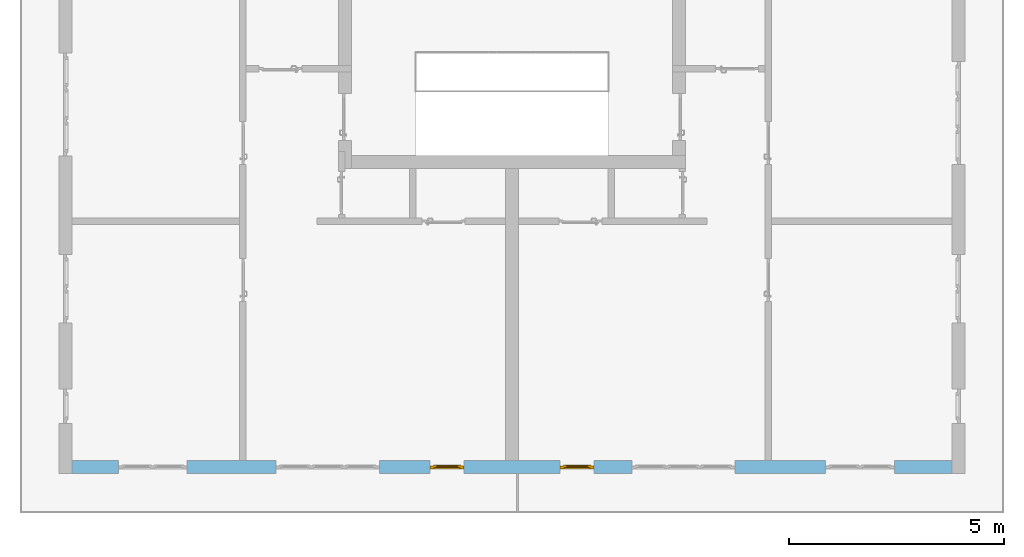
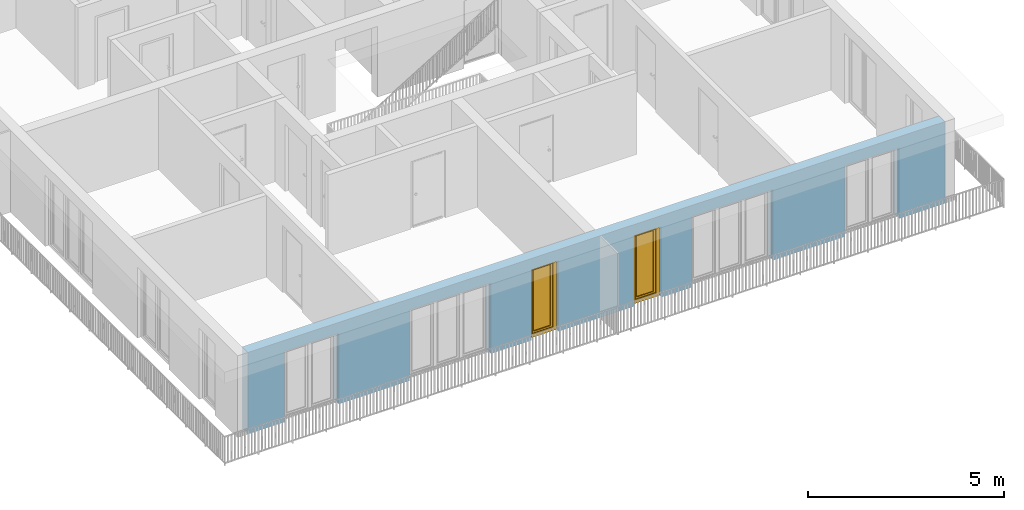
# One storey, part 10 of 54: 2 windows, 6 openings, plus 1 element that does not belong to this part.
"""IFC4 building model written with IfcOpenShell, lengths in metres."""

from ifc_helpers import new_model, entity, si_unit, converted_unit, derived_unit, direction, frame, origin_with_axes, place, context, subcontext, project, spatial, polygons, source, transform, mapped, material, type_object, element, fill, save


model = new_model("IFC4")

# Units and contexts
model_context = context("Model", 3, precision=1e-05, world=origin_with_axes(), true_north=direction((0.0, 1.0)))
body_context = subcontext(model_context, "Body", "Model", "MODEL_VIEW")
ifc_project = project(units=[si_unit("LENGTHUNIT", "METRE"), si_unit("AREAUNIT", "SQUARE_METRE"), si_unit("VOLUMEUNIT", "CUBIC_METRE"), converted_unit("PLANEANGLEUNIT", "DEGREE", entity("IfcPlaneAngleMeasure", 0.0174532925199), si_unit("PLANEANGLEUNIT", "RADIAN"), dimensions=[0, 0, 0, 0, 0, 0, 0]), converted_unit("TIMEUNIT", "Year", entity("IfcTimeMeasure", 31556926.0), si_unit("TIMEUNIT", "SECOND"), dimensions=[0, 0, 1, 0, 0, 0, 0]), si_unit("MASSUNIT", "GRAM", prefix="KILO"), si_unit("THERMODYNAMICTEMPERATUREUNIT", "DEGREE_CELSIUS"), si_unit("LUMINOUSINTENSITYUNIT", "LUMEN"), si_unit("ENERGYUNIT", "JOULE", prefix="MEGA"), derived_unit("THERMALCONDUCTANCEUNIT", [(si_unit("POWERUNIT", "WATT"), 1), (si_unit("LENGTHUNIT", "METRE"), -1), (si_unit("THERMODYNAMICTEMPERATUREUNIT", "KELVIN"), -1)]), derived_unit("SPECIFICHEATCAPACITYUNIT", [(si_unit("ENERGYUNIT", "JOULE"), 1), (si_unit("MASSUNIT", "GRAM", prefix="KILO"), -1), (si_unit("THERMODYNAMICTEMPERATUREUNIT", "KELVIN"), -1)]), derived_unit("MASSDENSITYUNIT", [(si_unit("MASSUNIT", "GRAM", prefix="KILO"), 1), (si_unit("VOLUMEUNIT", "CUBIC_METRE"), -1)])], contexts=[model_context])

# Site, building, storey
site_placement = place(None, origin_with_axes())
site = spatial("IfcSite", under=ifc_project, at=site_placement, CompositionType="ELEMENT")
building_placement = place(site_placement, origin_with_axes())
building = spatial("IfcBuilding", under=site, at=building_placement, CompositionType="ELEMENT")
storey_placement = place(building_placement, frame((0.0, 0.0, 6.29), z_axis=(0.0, 0.0, 1.0), x_axis=(1.0, 0.0, 0.0)))
storey = spatial("IfcBuildingStorey", under=building, at=storey_placement, Name="2. Geschoss", CompositionType="ELEMENT", Elevation=6.29)

# Wall, openings, windows
ifc_material = material()
wall_type = type_object("IfcWallType", Name="300", PredefinedType="NOTDEFINED")
wall_placement = place(storey_placement, frame((9.3378006196, -9.92881223104, 0.0), z_axis=(0.0, 0.0, 1.0), x_axis=(-1.0, 0.0, 0.0)))
wall = element("IfcWall", 1, at=wall_placement, inside=storey, type_object=wall_type, material=ifc_material, Name="Wand-001", PredefinedType="NOTDEFINED", context=body_context, shape_type="Tessellation", body=[
    polygons([(12.4515538751, -0.3, 2.2), (12.4515538751, -0.3, 0.0), (13.63, -0.3, 0.0), (13.63, -0.3, 2.2), (16.03, -0.3, 2.2), (16.03, -0.3, 0.0), (18.0998837323, -0.3, 0.0), (18.0998837323, -0.3, 2.2), (19.6998837323, -0.3, 2.2), (19.6998837323, -0.3, 0.0), (20.78, -0.3, 0.0), (20.78, -0.3, 2.54), (0.3, -0.3, 2.54), (0.3, -0.3, 0.0), (1.6378225413, -0.3, 0.0), (1.6378225413, -0.3, 2.2), (3.2378225413, -0.3, 2.2), (3.2378225413, -0.3, 0.0), (5.35, -0.3, 0.0), (5.35, -0.3, 2.2), (7.75, -0.3, 2.2), (7.75, -0.3, 0.0), (8.62617854928, -0.3, 0.0), (8.62617854928, -0.3, 2.2), (9.42617854928, -0.3, 2.2), (9.42617854928, -0.3, 0.0), (11.6515538751, -0.3, 0.0), (11.6515538751, -0.3, 2.2), (12.4515538751, -0.1, 0.0), (12.4515538751, 0.0, 2.2), (12.4515538751, 0.0, 0.0), (13.63, 0.0, 0.0), (13.63, 0.0, 2.2), (16.03, 0.0, 2.2), (16.03, 0.0, 0.0), (18.0998837323, 0.0, 0.0), (18.0998837323, 0.0, 2.2), (19.6998837323, 0.0, 2.2), (19.6998837323, 0.0, 0.0), (20.78, 0.0, 0.0), (20.78, 0.0, 2.54), (0.3, 0.0, 2.54), (0.3, 0.0, 0.0), (1.6378225413, 0.0, 0.0), (1.6378225413, 0.0, 2.2), (3.2378225413, 0.0, 2.2), (3.2378225413, 0.0, 0.0), (5.35, 0.0, 0.0), (5.35, 0.0, 2.2), (7.75, 0.0, 2.2), (7.75, 0.0, 0.0), (8.62617854928, 0.0, 0.0), (8.62617854928, 0.0, 2.2), (9.42617854928, 0.0, 2.2), (9.42617854928, 0.0, 0.0), (11.6515538751, -0.1, 0.0), (11.6515538751, 0.0, 0.0), (11.6515538751, 0.0, 2.2)], [[[1, 2, 3, 4, 5, 6, 7, 8, 9, 10, 11, 12, 13, 14, 15, 16, 17, 18, 19, 20, 21, 22, 23, 24, 25, 26, 27, 28]], [[29, 2, 1, 30, 31]], [[2, 29, 31, 32, 3]], [[32, 33, 4, 3]], [[33, 34, 5, 4]], [[34, 35, 6, 5]], [[36, 7, 6, 35]], [[36, 37, 8, 7]], [[37, 38, 9, 8]], [[38, 39, 10, 9]], [[40, 11, 10, 39]], [[40, 41, 12, 11]], [[41, 42, 13, 12]], [[14, 13, 42, 43]], [[15, 14, 43, 44]], [[16, 15, 44, 45]], [[17, 16, 45, 46]], [[18, 17, 46, 47]], [[19, 18, 47, 48]], [[20, 19, 48, 49]], [[21, 20, 49, 50]], [[22, 21, 50, 51]], [[51, 52, 23, 22]], [[52, 53, 24, 23]], [[53, 54, 25, 24]], [[54, 55, 26, 25]], [[56, 27, 26, 55, 57]], [[28, 27, 56, 57, 58]], [[1, 28, 58, 30]], [[32, 31, 30, 58, 57, 55, 54, 53, 52, 51, 50, 49, 48, 47, 46, 45, 44, 43, 42, 41, 40, 39, 38, 37, 36, 35, 34, 33]]], closed=True),
])
opening_1_placement = place(wall_placement, frame((18.8998837323, 0.0, 0.0), z_axis=(0.0, 0.0, 1.0), x_axis=(1.0, 0.0, 0.0)))
element("IfcOpeningElement", 2, at=opening_1_placement, cuts=wall, Name="Fenster-001", context=body_context, identifier="Reference", shape_type="Tessellation", body=[
    polygons([(-0.8, -0.1, 0.0), (-0.8, -0.1, 2.2), (-0.8, 0.001, 2.2), (-0.8, 0.001, 0.0), (-0.8, -0.301, 0.0), (-0.8, -0.301, 2.2), (0.8, -0.1, 2.2), (0.8, 0.001, 2.2), (0.8, -0.301, 2.2), (0.8, 0.001, 0.0), (0.8, -0.1, 0.0), (0.8, -0.301, 0.0)], [[[1, 2, 3, 4]], [[2, 1, 5, 6]], [[7, 8, 3, 2, 6, 9]], [[8, 10, 4, 3]], [[1, 4, 10, 11, 12, 5]], [[6, 5, 12, 9]], [[7, 11, 10, 8]], [[11, 7, 9, 12]]], closed=True),
])
opening_2_placement = place(wall_placement, frame((2.4378225413, 0.0, 0.0), z_axis=(0.0, 0.0, 1.0), x_axis=(1.0, 0.0, 0.0)))
element("IfcOpeningElement", 3, at=opening_2_placement, cuts=wall, Name="Fenster-002", context=body_context, identifier="Reference", shape_type="Tessellation", body=[
    polygons([(-0.8, -0.1, 0.0), (-0.8, -0.1, 2.2), (-0.8, 0.000999999999999, 2.2), (-0.8, 0.000999999999999, 0.0), (-0.8, -0.301, 0.0), (-0.8, -0.301, 2.2), (0.8, -0.1, 2.2), (0.8, 0.000999999999999, 2.2), (0.8, -0.301, 2.2), (0.8, 0.000999999999999, 0.0), (0.8, -0.1, 0.0), (0.8, -0.301, 0.0)], [[[1, 2, 3, 4]], [[2, 1, 5, 6]], [[7, 8, 3, 2, 6, 9]], [[8, 10, 4, 3]], [[1, 4, 10, 11, 12, 5]], [[6, 5, 12, 9]], [[7, 11, 10, 8]], [[11, 7, 9, 12]]], closed=True),
])
opening_3_placement = place(wall_placement, frame((14.83, 0.0, 0.0), z_axis=(0.0, 0.0, 1.0), x_axis=(1.0, 0.0, 0.0)))
element("IfcOpeningElement", 4, at=opening_3_placement, cuts=wall, Name="Fenster-002", context=body_context, identifier="Reference", shape_type="Tessellation", body=[
    polygons([(-1.2, -0.1, 0.0), (-1.2, -0.1, 2.2), (-1.2, 0.001, 2.2), (-1.2, 0.001, 0.0), (-1.2, -0.301, 0.0), (-1.2, -0.301, 2.2), (1.2, -0.1, 2.2), (1.2, 0.001, 2.2), (1.2, -0.301, 2.2), (1.2, 0.001, 0.0), (1.2, -0.1, 0.0), (1.2, -0.301, 0.0)], [[[1, 2, 3, 4]], [[2, 1, 5, 6]], [[7, 8, 3, 2, 6, 9]], [[8, 10, 4, 3]], [[1, 4, 10, 11, 12, 5]], [[6, 5, 12, 9]], [[7, 11, 10, 8]], [[11, 7, 9, 12]]], closed=True),
])
opening_4_placement = place(wall_placement, frame((6.55, 0.0, 0.0), z_axis=(0.0, 0.0, 1.0), x_axis=(1.0, 0.0, 0.0)))
element("IfcOpeningElement", 5, at=opening_4_placement, cuts=wall, Name="Fenster-003", context=body_context, identifier="Reference", shape_type="Tessellation", body=[
    polygons([(-1.2, -0.1, 0.0), (-1.2, -0.1, 2.2), (-1.2, 0.000999999999999, 2.2), (-1.2, 0.000999999999999, 0.0), (-1.2, -0.301, 0.0), (-1.2, -0.301, 2.2), (1.2, -0.1, 2.2), (1.2, 0.001, 2.2), (1.2, -0.301, 2.2), (1.2, 0.001, 0.0), (1.2, -0.1, 0.0), (1.2, -0.301, 0.0)], [[[1, 2, 3, 4]], [[2, 1, 5, 6]], [[7, 8, 3, 2, 6, 9]], [[8, 10, 4, 3]], [[1, 4, 10, 11, 12, 5]], [[6, 5, 12, 9]], [[7, 11, 10, 8]], [[11, 7, 9, 12]]], closed=True),
])
opening_5_placement = place(wall_placement, frame((9.02617854928, 0.0, 0.0), z_axis=(0.0, 0.0, 1.0), x_axis=(1.0, 0.0, 0.0)))
opening_5 = element("IfcOpeningElement", 6, at=opening_5_placement, cuts=wall, Name="Fenster-003", context=body_context, identifier="Reference", shape_type="Tessellation", body=[
    polygons([(-0.4, -0.1, 0.0), (-0.4, -0.1, 2.2), (-0.4, 0.001, 2.2), (-0.4, 0.001, 0.0), (-0.4, -0.301, 0.0), (-0.4, -0.301, 2.2), (0.4, -0.1, 2.2), (0.4, 0.001, 2.2), (0.4, -0.301, 2.2), (0.4, 0.001, 0.0), (0.4, -0.1, 0.0), (0.4, -0.301, 0.0)], [[[1, 2, 3, 4]], [[2, 1, 5, 6]], [[7, 8, 3, 2, 6, 9]], [[8, 10, 4, 3]], [[1, 4, 10, 11, 12, 5]], [[6, 5, 12, 9]], [[7, 11, 10, 8]], [[11, 7, 9, 12]]], closed=True),
])
opening_6_placement = place(wall_placement, frame((12.0515538751, 0.0, 0.0), z_axis=(0.0, 0.0, 1.0), x_axis=(1.0, 0.0, 0.0)))
opening_6 = element("IfcOpeningElement", 7, at=opening_6_placement, cuts=wall, Name="Fenster-003", context=body_context, identifier="Reference", shape_type="Tessellation", body=[
    polygons([(-0.4, -0.1, 0.0), (-0.4, -0.1, 2.2), (-0.4, 0.001, 2.2), (-0.4, 0.001, 0.0), (-0.4, -0.301, 0.0), (-0.4, -0.301, 2.2), (0.4, -0.1, 2.2), (0.4, 0.001, 2.2), (0.4, -0.301, 2.2), (0.4, 0.001, 0.0), (0.4, -0.1, 0.0), (0.4, -0.301, 0.0)], [[[1, 2, 3, 4]], [[2, 1, 5, 6]], [[7, 8, 3, 2, 6, 9]], [[8, 10, 4, 3]], [[1, 4, 10, 11, 12, 5]], [[6, 5, 12, 9]], [[7, 11, 10, 8]], [[11, 7, 9, 12]]], closed=True),
])
window_type = type_object("IfcWindowType", Name="1-26", PartitioningType="SINGLE_PANEL", PredefinedType="WINDOW")
shared_shape = source(origin_with_axes(), body_context, "Body", "Tessellation", [
    polygons([(-0.4, -0.07, 0.0), (-0.4, 0.0, 0.0), (-0.3, 0.0, 0.1), (-0.3, -0.07, 0.1), (-0.4, -0.07, 2.2), (-0.4, 0.0, 2.2), (-0.3, 0.0, 2.1), (-0.3, -0.07, 2.1)], [[[1, 2, 3, 4]], [[5, 6, 2, 1]], [[2, 6, 7, 3]], [[4, 3, 7, 8]], [[1, 4, 8, 5]], [[8, 7, 6, 5]]], closed=True),
    polygons([(0.4, -0.07, 0.0), (0.4, 0.0, 0.0), (0.4, 0.0, 2.2), (0.4, -0.07, 2.2), (0.3, -0.07, 0.1), (0.3, 0.0, 0.1), (0.3, 0.0, 2.1), (0.3, -0.07, 2.1)], [[[1, 2, 3, 4]], [[5, 6, 2, 1]], [[2, 6, 7, 3]], [[4, 3, 7, 8]], [[1, 4, 8, 5]], [[8, 7, 6, 5]]], closed=True),
    polygons([(-0.4, -0.07, 0.0), (-0.4, 0.0, 0.0), (0.4, 0.0, 0.0), (0.4, -0.07, 0.0), (-0.3, -0.07, 0.1), (-0.3, 0.0, 0.1), (0.0, 0.0, 0.1), (0.3, 0.0, 0.1), (0.3, -0.07, 0.1), (0.0, -0.07, 0.1)], [[[1, 2, 3, 4]], [[5, 6, 2, 1]], [[2, 6, 7, 8, 3]], [[4, 3, 8, 9]], [[1, 4, 9, 10, 5]], [[10, 7, 6, 5]], [[9, 8, 7, 10]]], closed=True),
    polygons([(-0.4, -0.07, 2.2), (-0.4, 0.0, 2.2), (-0.3, 0.0, 2.1), (-0.3, -0.07, 2.1), (0.4, -0.07, 2.2), (0.4, 0.0, 2.2), (0.3, 0.0, 2.1), (0.0, 0.0, 2.1), (0.0, -0.07, 2.1), (0.3, -0.07, 2.1)], [[[1, 2, 3, 4]], [[5, 6, 2, 1]], [[2, 6, 7, 8, 3]], [[4, 3, 8, 9]], [[1, 4, 9, 10, 5]], [[10, 7, 6, 5]], [[9, 8, 7, 10]]], closed=True),
    polygons([(-0.32, 0.0, 0.08), (-0.32, 0.03, 0.08), (-0.25, 0.03, 0.15), (-0.25, 0.0, 0.15), (-0.32, 0.0, 2.12), (-0.32, 0.03, 2.12), (-0.25, 0.03, 2.05), (-0.25, 0.0, 2.05)], [[[1, 2, 3, 4]], [[5, 6, 2, 1]], [[2, 6, 7, 3]], [[4, 3, 7, 8]], [[1, 4, 8, 5]], [[8, 7, 6, 5]]], closed=True),
    polygons([(0.32, 0.0, 0.08), (0.25, 0.0, 0.15), (0.25, 0.03, 0.15), (0.32, 0.03, 0.08), (0.32, 0.0, 2.12), (0.25, 0.0, 2.05), (0.25, 0.03, 2.05), (0.32, 0.03, 2.12)], [[[1, 2, 3, 4]], [[1, 5, 6, 2]], [[2, 6, 7, 3]], [[4, 3, 7, 8]], [[5, 1, 4, 8]], [[6, 5, 8, 7]]], closed=True),
    polygons([(-0.32, 0.0, 0.08), (-0.32, 0.03, 0.08), (0.32, 0.03, 0.08), (0.32, 0.0, 0.08), (-0.25, 0.0, 0.15), (-0.25, 0.03, 0.15), (0.25, 0.03, 0.15), (0.25, 0.0, 0.15)], [[[1, 2, 3, 4]], [[5, 6, 2, 1]], [[2, 6, 7, 3]], [[4, 3, 7, 8]], [[1, 4, 8, 5]], [[8, 7, 6, 5]]], closed=True),
    polygons([(-0.32, 0.0, 2.12), (0.32, 0.0, 2.12), (0.32, 0.03, 2.12), (-0.32, 0.03, 2.12), (-0.25, 0.0, 2.05), (0.25, 0.0, 2.05), (0.25, 0.03, 2.05), (-0.25, 0.03, 2.05)], [[[1, 2, 3, 4]], [[1, 5, 6, 2]], [[2, 6, 7, 3]], [[4, 3, 7, 8]], [[5, 1, 4, 8]], [[6, 5, 8, 7]]], closed=True),
    polygons([(-0.3, -0.03, 0.1), (-0.3, 0.0, 0.1), (-0.25, 0.0, 0.15), (-0.25, -0.03, 0.15), (-0.3, -0.03, 2.1), (-0.3, 0.0, 2.1), (-0.25, 0.0, 2.05), (-0.25, -0.03, 2.05)], [[[1, 2, 3, 4]], [[5, 6, 2, 1]], [[2, 6, 7, 3]], [[4, 3, 7, 8]], [[1, 4, 8, 5]], [[8, 7, 6, 5]]], closed=True),
    polygons([(0.3, -0.03, 0.1), (0.25, -0.03, 0.15), (0.25, 0.0, 0.15), (0.3, 0.0, 0.1), (0.3, -0.03, 2.1), (0.25, -0.03, 2.05), (0.25, 0.0, 2.05), (0.3, 0.0, 2.1)], [[[1, 2, 3, 4]], [[1, 5, 6, 2]], [[2, 6, 7, 3]], [[4, 3, 7, 8]], [[5, 1, 4, 8]], [[6, 5, 8, 7]]], closed=True),
    polygons([(-0.3, -0.03, 0.1), (-0.3, 0.0, 0.1), (0.3, 0.0, 0.1), (0.3, -0.03, 0.1), (-0.25, -0.03, 0.15), (-0.25, 0.0, 0.15), (0.25, 0.0, 0.15), (0.25, -0.03, 0.15)], [[[1, 2, 3, 4]], [[5, 6, 2, 1]], [[2, 6, 7, 3]], [[4, 3, 7, 8]], [[1, 4, 8, 5]], [[8, 7, 6, 5]]], closed=True),
    polygons([(-0.3, -0.03, 2.1), (0.3, -0.03, 2.1), (0.3, 0.0, 2.1), (-0.3, 0.0, 2.1), (-0.25, -0.03, 2.05), (0.25, -0.03, 2.05), (0.25, 0.0, 2.05), (-0.25, 0.0, 2.05)], [[[1, 2, 3, 4]], [[1, 5, 6, 2]], [[2, 6, 7, 3]], [[4, 3, 7, 8]], [[5, 1, 4, 8]], [[6, 5, 8, 7]]], closed=True),
    polygons([(-0.25, -0.005, 0.15), (-0.25, 0.005, 0.15), (0.25, 0.005, 0.15), (0.25, -0.005, 0.15), (-0.25, -0.005, 2.05), (-0.25, 0.005, 2.05), (0.25, 0.005, 2.05), (0.25, -0.005, 2.05)], [[[1, 2, 3, 4]], [[5, 6, 2, 1]], [[2, 6, 7, 3]], [[4, 3, 7, 8]], [[1, 4, 8, 5]], [[8, 7, 6, 5]]], closed=True),
])
window_1_placement = place(opening_5_placement, frame((0.4, 0.0, 0.0), z_axis=(0.0, 0.0, 1.0), x_axis=(-1.0, 0.0, 0.0)))
window_1 = element("IfcWindow", 8, at=window_1_placement, inside=storey, type_object=window_type, Name="Fenster-003", OverallHeight=2.2, OverallWidth=0.8, PredefinedType="WINDOW", context=body_context, shape_type="MappedRepresentation", body=[
    mapped(shared_shape, transform((0.4, 0.17, 0.0))),
])
fill(opening_5, window_1)
window_2_placement = place(opening_6_placement, frame((0.4, 0.0, 0.0), z_axis=(0.0, 0.0, 1.0), x_axis=(-1.0, 0.0, 0.0)))
window_2 = element("IfcWindow", 9, at=window_2_placement, inside=storey, type_object=window_type, Name="Fenster-003", OverallHeight=2.2, OverallWidth=0.8, PredefinedType="WINDOW", context=body_context, shape_type="MappedRepresentation", body=[
    mapped(shared_shape, transform((0.4, 0.17, 0.0))),
])
fill(opening_6, window_2)

save(model, "model.ifc")
